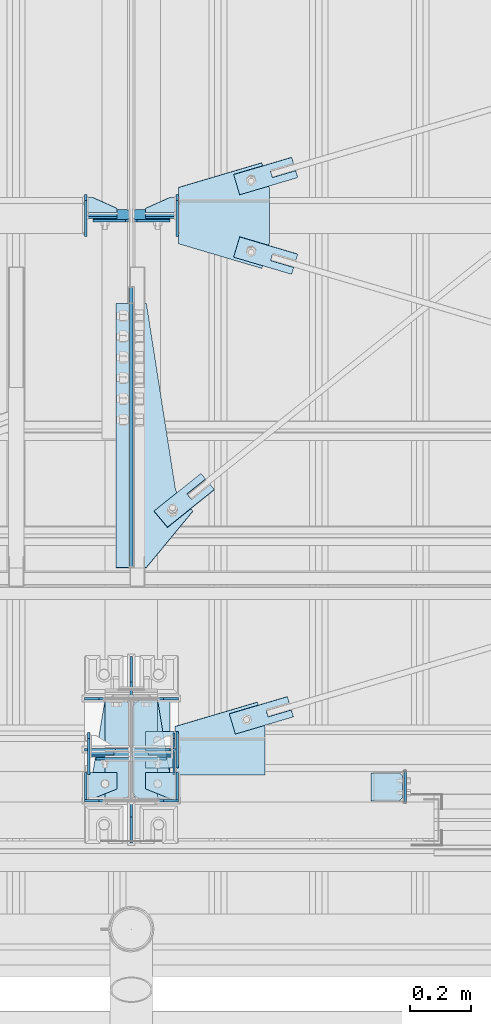
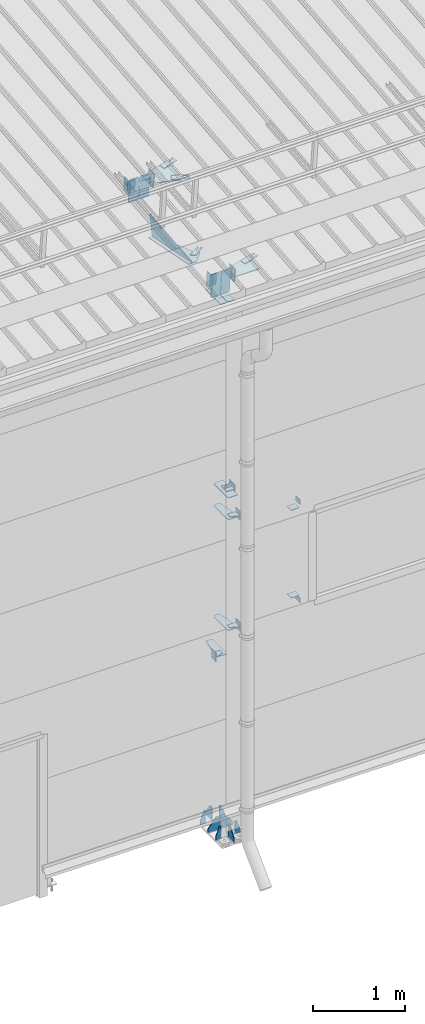
# One storey, part 108 of 709: 49 plates, 3 openings, 15 elements without a shape of their own.
"""IFC4 building model written with IfcOpenShell, lengths in millimetres."""

import ifcopenshell
import ifcopenshell.guid

model = None  # the IFC model being written
_history = None  # IfcOwnerHistory: only IFC2X3 demands one
_inside = {}  # id of a spatial element -> (the spatial element, [elements in it])
_under = {}  # id of a project, library or spatial element -> (it, [spatial elements below it])
_declared = {}  # id of a project -> (the project, [libraries it declares])
_typed = {}  # id of a type object -> (the type object, [elements of that type])
_made_of = {}  # id of a material, layer set ... -> (it, [elements and type objects made of it])


def new_model(schema):
    """Start an empty IFC model of exactly this schema.

    Asked for "IFC4X3", IfcOpenShell would pick the latest addendum, in which some entities
    have other attributes; the version numbers below select the first issue.
    IFC2X3 requires an IfcOwnerHistory on every rooted entity: one is made here for all.
    """
    global model, _history
    if schema == "IFC4X3":
        model = ifcopenshell.file(schema_version=(4, 3, 0, 0))
    else:
        model = ifcopenshell.file(schema=schema)
    _inside.clear()
    _under.clear()
    _declared.clear()
    _typed.clear()
    _made_of.clear()
    _history = None
    if model.schema == "IFC2X3":
        org = make("IfcOrganization", Name="unknown")
        user = make(
            "IfcPersonAndOrganization",
            ThePerson=make("IfcPerson", FamilyName="unknown"),
            TheOrganization=org,
        )
        app = make(
            "IfcApplication",
            ApplicationDeveloper=org,
            Version="unknown",
            ApplicationFullName="unknown",
            ApplicationIdentifier="unknown",
        )
        _history = make(
            "IfcOwnerHistory",
            OwningUser=user,
            OwningApplication=app,
            ChangeAction="ADDED",
            CreationDate=0,
        )
    return model


def make(cls, **values):
    """One entity of the class cls with the attributes given. An attribute that is None is left unset."""
    return model.create_entity(
        cls, **{name: value for name, value in values.items() if value is not None}
    )


def rooted(cls, **values):
    """An entity with a GlobalId (a new one), such as an element, a storey or a relation."""
    return make(cls, GlobalId=ifcopenshell.guid.new(), OwnerHistory=_history, **values)


def si_unit(unit_type, name, prefix=None):
    """IfcSIUnit, for example si_unit("LENGTHUNIT", "METRE", prefix="MILLI")."""
    return make("IfcSIUnit", UnitType=unit_type, Prefix=prefix, Name=name)


def assignment(units):
    """IfcUnitAssignment: the units of a project."""
    return None if units is None else make("IfcUnitAssignment", Units=units)


def point(xyz):
    """IfcCartesianPoint."""
    return None if xyz is None else make("IfcCartesianPoint", Coordinates=xyz)


def direction(xyz):
    """IfcDirection."""
    return None if xyz is None else make("IfcDirection", DirectionRatios=xyz)


def frame(location, z_axis=None, x_axis=None):
    """IfcAxis2Placement3D, a coordinate frame: its origin and axes. An axis left out is left unset."""
    return make(
        "IfcAxis2Placement3D",
        Location=point(location),
        Axis=direction(z_axis),
        RefDirection=direction(x_axis),
    )


def origin_with_axes():
    """The frame at (0, 0, 0) with the z axis (0, 0, 1) and the x axis (1, 0, 0) written out."""
    return frame((0.0, 0.0, 0.0), z_axis=(0.0, 0.0, 1.0), x_axis=(1.0, 0.0, 0.0))


def place(relative_to, where):
    """IfcLocalPlacement: puts the frame where relative to a parent placement (None: the world)."""
    return make(
        "IfcLocalPlacement", PlacementRelTo=relative_to, RelativePlacement=where
    )


def context(
    kind, dimensions, precision=None, world=None, true_north=None, identifier=None
):
    """IfcGeometricRepresentationContext, for example the 3D "Model" context."""
    return make(
        "IfcGeometricRepresentationContext",
        ContextIdentifier=identifier,
        ContextType=kind,
        CoordinateSpaceDimension=dimensions,
        Precision=precision,
        WorldCoordinateSystem=world,
        TrueNorth=true_north,
    )


def subcontext(parent, identifier, kind, view, scale=None):
    """IfcGeometricRepresentationSubContext, for example "Body" below "Model"."""
    return make(
        "IfcGeometricRepresentationSubContext",
        ContextIdentifier=identifier,
        ContextType=kind,
        ParentContext=parent,
        TargetScale=scale,
        TargetView=view,
    )


def project(units=None, contexts=None):
    """IfcProject with its units and contexts."""
    return rooted(
        "IfcProject",
        Name="project",
        RepresentationContexts=contexts,
        UnitsInContext=assignment(units),
    )


def spatial(cls, under=None, at=None, **own):
    """A site, building, storey or space (cls), placed at a placement, below another one or the project."""
    s = rooted(cls, ObjectPlacement=at, **own)
    if under is not None:
        _under.setdefault(under.id(), (under, []))[1].append(s)
    return s


def point_list(points):
    """IfcCartesianPointList2D or 3D."""
    cls = (
        "IfcCartesianPointList2D" if len(points[0]) == 2 else "IfcCartesianPointList3D"
    )
    return make(cls, CoordList=points)


def line(*indices):
    """IfcLineIndex: a straight run through numbered points of an indexed curve."""
    return model.create_entity("IfcLineIndex", indices)


def indexed_curve(points, segments=None, self_intersect=None):
    """IfcIndexedPolyCurve: lines and arcs through numbered points (the first is 1)."""
    return make(
        "IfcIndexedPolyCurve",
        Points=point_list(points),
        Segments=segments,
        SelfIntersect=self_intersect,
    )


def outline(outer, holes=None, kind="AREA"):
    """IfcArbitraryClosedProfileDef: a profile drawn as a closed curve; with holes, ...WithVoids."""
    if holes is None:
        return make("IfcArbitraryClosedProfileDef", ProfileType=kind, OuterCurve=outer)
    return make(
        "IfcArbitraryProfileDefWithVoids",
        ProfileType=kind,
        OuterCurve=outer,
        InnerCurves=holes,
    )


def extrude(swept, where, along, depth):
    """IfcExtrudedAreaSolid: the profile swept, set in the frame where, extruded along a direction by depth."""
    return make(
        "IfcExtrudedAreaSolid",
        SweptArea=swept,
        Position=where,
        ExtrudedDirection=direction(along),
        Depth=depth,
    )


def shape(context_of_items, identifier, shape_type, items):
    """IfcShapeRepresentation: the items that make up one representation, for example the "Body"."""
    return make(
        "IfcShapeRepresentation",
        ContextOfItems=context_of_items,
        RepresentationIdentifier=identifier,
        RepresentationType=shape_type,
        Items=items,
    )


def material(Name=None, Category=None):
    """IfcMaterial."""
    return make("IfcMaterial", Name=Name, Category=Category)


def made_of(thing, what):
    """Note that an element or type object is made of a material, layer set ...; save() writes the relation."""
    if what is not None:
        _made_of.setdefault(what.id(), (what, []))[1].append(thing)
    return thing


def element(
    cls,
    number,
    at=None,
    inside=None,
    cuts=None,
    type_object=None,
    material=None,
    context=None,
    identifier="Body",
    shape_type=None,
    held_by="IfcProductDefinitionShape",
    body=None,
    shapes=None,
    **own,
):
    """One element of the class cls, such as IfcWall. Its Tag is "e" and its number.

    at: its placement. inside: the storey or other place that contains it. cuts: it is an
    opening in that element (IfcRelVoidsElement). A single representation is given by context,
    identifier, shape_type and body (its items); several are given by shapes. held_by: the class
    of the entity that holds the representations. save() writes the other relations.
    """
    e = rooted(cls, Tag="e%d" % number, ObjectPlacement=at, **own)
    if body is not None:
        shapes = [shape(context, identifier, shape_type, body)]
    if shapes is not None:
        e.Representation = make(held_by, Representations=shapes)
    if inside is not None:
        _inside.setdefault(inside.id(), (inside, []))[1].append(e)
    if cuts is not None:
        rooted(
            "IfcRelVoidsElement", RelatingBuildingElement=cuts, RelatedOpeningElement=e
        )
    if type_object is not None:
        _typed.setdefault(type_object.id(), (type_object, []))[1].append(e)
    return made_of(e, material)


def aggregate(whole, parts):
    """IfcRelAggregates: a whole, such as a stair, and the parts it consists of."""
    return rooted("IfcRelAggregates", RelatingObject=whole, RelatedObjects=parts)


def save(model, path):
    """Write the relations noted so far, then the file.

    IfcRelAggregates (storeys below a building ...), IfcRelContainedInSpatialStructure (elements
    in a storey), IfcRelDefinesByType, IfcRelAssociatesMaterial and IfcRelDeclares: one each for
    every whole, place, type object, material and project.
    """
    for whole, parts in _under.values():
        aggregate(whole, parts)
    for where, things in _inside.values():
        rooted(
            "IfcRelContainedInSpatialStructure",
            RelatedElements=things,
            RelatingStructure=where,
        )
    for kind, things in _typed.values():
        rooted("IfcRelDefinesByType", RelatedObjects=things, RelatingType=kind)
    for what, things in _made_of.values():
        rooted("IfcRelAssociatesMaterial", RelatedObjects=things, RelatingMaterial=what)
    for by, libraries in _declared.values():
        rooted("IfcRelDeclares", RelatingContext=by, RelatedDefinitions=libraries)
    model.write(path)


model = new_model("IFC4")

# Units and contexts
model_context = context("Model", 3, precision=0.2, world=origin_with_axes(), true_north=direction((0.0, 1.0)))
body_context = subcontext(model_context, "Body", "Model", "MODEL_VIEW")
ifc_project = project(units=[si_unit("LENGTHUNIT", "METRE", prefix="MILLI"), si_unit("AREAUNIT", "SQUARE_METRE"), si_unit("VOLUMEUNIT", "CUBIC_METRE"), si_unit("MASSUNIT", "GRAM", prefix="KILO"), si_unit("TIMEUNIT", "SECOND"), si_unit("PLANEANGLEUNIT", "RADIAN"), si_unit("SOLIDANGLEUNIT", "STERADIAN"), si_unit("THERMODYNAMICTEMPERATUREUNIT", "DEGREE_CELSIUS"), si_unit("LUMINOUSINTENSITYUNIT", "LUMEN")], contexts=[model_context])

# Site, building, storey
site_placement = place(None, origin_with_axes())
site = spatial("IfcSite", under=ifc_project, at=site_placement, CompositionType="ELEMENT")
building_placement = place(site_placement, origin_with_axes())
building = spatial("IfcBuilding", under=site, at=building_placement, Name="Undefined", CompositionType="ELEMENT")
storey_placement = place(building_placement, origin_with_axes())
storey = spatial("IfcBuildingStorey", under=building, at=storey_placement, Name="Undefined", CompositionType="ELEMENT", Elevation=0.0)

# Assembly, plates
assembly_1_placement = place(storey_placement, frame((4000.0, 173.0, -200.0), z_axis=(-1.0, 0.0, 0.0), x_axis=(0.0, 0.0, 1.0)))
assembly_1 = element("IfcElementAssembly", 1, at=assembly_1_placement, inside=storey)
ifc_material = material(Name="C355-6", Category="STEEL")
plate_1_placement = place(assembly_1_placement, frame((25.0, -168.5, -87.0), z_axis=(0.0, -1.0, 0.0), x_axis=(0.0, 0.0, -1.0)))
plate_1 = element("IfcPlate", 2, at=plate_1_placement, material=ifc_material, ObjectType="419", context=body_context, shape_type="SolidModel", body=[
    extrude(outline(indexed_curve([(0.0, 0.0), (68.0, 0.0), (68.0, 50.0), (20.0, 175.0), (0.0, 175.0)], segments=[line(1, 2, 3, 4, 5, 1)])), frame((0.0, 0.0, 4.0), z_axis=(0.0, 0.0, 1.0), x_axis=(1.0, 0.0, 0.0)), (0.0, 0.0, -1.0), 8.0),
])
plate_2_placement = place(assembly_1_placement, frame((25.0, 168.5, -87.0), z_axis=(0.0, -1.0, 0.0), x_axis=(0.0, 0.0, -1.0)))
plate_2 = element("IfcPlate", 3, at=plate_2_placement, material=ifc_material, ObjectType="419", context=body_context, shape_type="SolidModel", body=[
    extrude(outline(indexed_curve([(0.0, 0.0), (68.0, 0.0), (68.0, 50.0), (20.0, 175.0), (0.0, 175.0)], segments=[line(1, 2, 3, 4, 5, 1)])), frame((0.0, 0.0, 4.0), z_axis=(0.0, 0.0, 1.0), x_axis=(1.0, 0.0, 0.0)), (0.0, 0.0, -1.0), 8.0),
])
plate_3_placement = place(assembly_1_placement, frame((25.0, 168.5, 87.0), z_axis=(0.0, 1.0, 0.0), x_axis=(0.0, 0.0, 1.0)))
plate_3 = element("IfcPlate", 4, at=plate_3_placement, material=ifc_material, ObjectType="419", context=body_context, shape_type="SolidModel", body=[
    extrude(outline(indexed_curve([(0.0, 0.0), (68.0, 0.0), (68.0, 50.0), (20.0, 175.0), (0.0, 175.0)], segments=[line(1, 2, 3, 4, 5, 1)])), frame((0.0, 0.0, 4.0), z_axis=(0.0, 0.0, 1.0), x_axis=(1.0, 0.0, 0.0)), (0.0, 0.0, -1.0), 8.0),
])
plate_4_placement = place(assembly_1_placement, frame((25.0, -168.5, 87.0), z_axis=(0.0, 1.0, 0.0), x_axis=(0.0, 0.0, 1.0)))
plate_4 = element("IfcPlate", 5, at=plate_4_placement, material=ifc_material, ObjectType="419", context=body_context, shape_type="SolidModel", body=[
    extrude(outline(indexed_curve([(0.0, 0.0), (68.0, 0.0), (68.0, 50.0), (20.0, 175.0), (0.0, 175.0)], segments=[line(1, 2, 3, 4, 5, 1)])), frame((0.0, 0.0, 4.0), z_axis=(0.0, 0.0, 1.0), x_axis=(1.0, 0.0, 0.0)), (0.0, 0.0, -1.0), 8.0),
])
plate_5_placement = place(assembly_1_placement, frame((25.0, 0.0, 3.0), z_axis=(0.0, 1.0, 0.0), x_axis=(0.0, 0.0, 1.0)))
plate_5 = element("IfcPlate", 6, at=plate_5_placement, material=ifc_material, ObjectType="417", context=body_context, shape_type="SolidModel", body=[
    extrude(outline(indexed_curve([(0.0, 0.0), (152.0, 0.0), (152.0, 50.0), (50.0, 175.0), (0.0, 175.0)], segments=[line(1, 2, 3, 4, 5, 1)])), frame((0.0, 0.0, 4.0), z_axis=(0.0, 0.0, 1.0), x_axis=(1.0, 0.0, 0.0)), (0.0, 0.0, -1.0), 8.0),
])
plate_6_placement = place(assembly_1_placement, frame((25.0, 173.0, 0.0), z_axis=(0.0, 0.0, -1.0), x_axis=(0.0, 1.0, 0.0)))
plate_6 = element("IfcPlate", 7, at=plate_6_placement, material=ifc_material, ObjectType="418", context=body_context, shape_type="SolidModel", body=[
    extrude(outline(indexed_curve([(0.0, 0.0), (135.0, 0.0), (135.0, 50.0), (50.0, 175.0), (0.0, 175.0)], segments=[line(1, 2, 3, 4, 5, 1)])), frame((0.0, 0.0, 4.0), z_axis=(0.0, 0.0, 1.0), x_axis=(1.0, 0.0, 0.0)), (0.0, 0.0, -1.0), 8.0),
])
plate_7_placement = place(assembly_1_placement, frame((25.0, -173.0, 0.0), z_axis=(0.0, 0.0, 1.0), x_axis=(0.0, -1.0, 0.0)))
plate_7 = element("IfcPlate", 8, at=plate_7_placement, material=ifc_material, ObjectType="418", context=body_context, shape_type="SolidModel", body=[
    extrude(outline(indexed_curve([(0.0, 0.0), (135.0, 0.0), (135.0, 50.0), (50.0, 175.0), (0.0, 175.0)], segments=[line(1, 2, 3, 4, 5, 1)])), frame((0.0, 0.0, 4.0), z_axis=(0.0, 0.0, 1.0), x_axis=(1.0, 0.0, 0.0)), (0.0, 0.0, -1.0), 8.0),
])
plate_8_placement = place(assembly_1_placement, frame((25.0, 0.0, -3.0), z_axis=(0.0, -1.0, 0.0), x_axis=(0.0, 0.0, -1.0)))
plate_8 = element("IfcPlate", 9, at=plate_8_placement, material=ifc_material, ObjectType="417", context=body_context, shape_type="SolidModel", body=[
    extrude(outline(indexed_curve([(0.0, 0.0), (152.0, 0.0), (152.0, 50.0), (50.0, 175.0), (0.0, 175.0)], segments=[line(1, 2, 3, 4, 5, 1)])), frame((0.0, 0.0, 4.0), z_axis=(0.0, 0.0, 1.0), x_axis=(1.0, 0.0, 0.0)), (0.0, 0.0, -1.0), 8.0),
])
plate_9_placement = place(assembly_1_placement, frame((7097.93718, 163.0, 87.0), z_axis=(-1.0, 0.0, 0.0), x_axis=(0.0, 0.0, -1.0)))
plate_9 = element("IfcPlate", 10, at=plate_9_placement, material=ifc_material, ObjectType="461", context=body_context, shape_type="SolidModel", body=[
    extrude(outline(indexed_curve([(0.0, 0.0), (68.0, 0.0), (83.0, 15.0), (83.0, 311.0), (68.0, 326.0), (0.0, 326.0)], segments=[line(1, 2, 3, 4, 5, 6, 1)])), frame((0.0, 0.0, 4.0), z_axis=(0.0, 0.0, 1.0), x_axis=(1.0, 0.0, 0.0)), (0.0, 0.0, -1.0), 8.0),
])
plate_10_placement = place(assembly_1_placement, frame((7097.93718, -163.0, -87.0), z_axis=(-1.0, 0.0, 0.0), x_axis=(0.0, 0.0, 1.0)))
plate_10 = element("IfcPlate", 11, at=plate_10_placement, material=ifc_material, ObjectType="461", context=body_context, shape_type="SolidModel", body=[
    extrude(outline(indexed_curve([(0.0, 0.0), (68.0, 0.0), (83.0, 15.0), (83.0, 311.0), (68.0, 326.0), (0.0, 326.0)], segments=[line(1, 2, 3, 4, 5, 6, 1)])), frame((0.0, 0.0, 4.0), z_axis=(0.0, 0.0, 1.0), x_axis=(1.0, 0.0, 0.0)), (0.0, 0.0, -1.0), 8.0),
])
plate_11_placement = place(assembly_1_placement, frame((2442.0, 163.0, 4.0), z_axis=(1.0, 0.0, 0.0), x_axis=(0.0, 0.0, 1.0)))
plate_11 = element("IfcPlate", 12, at=plate_11_placement, material=ifc_material, ObjectType="543", context=body_context, shape_type="SolidModel", body=[
    extrude(outline(indexed_curve([(0.0, 20.0), (20.0, 0.0), (83.0, 0.0), (123.0, 240.0), (123.0, 326.0), (20.0, 326.0), (0.0, 306.0)], segments=[line(1, 2, 3, 4, 5, 6, 7, 1)])), frame((0.0, 0.0, 4.0), z_axis=(0.0, 0.0, 1.0), x_axis=(1.0, 0.0, 0.0)), (0.0, 0.0, -1.0), 8.0),
])
plate_12_placement = place(assembly_1_placement, frame((2742.0, -163.0, -4.0), z_axis=(1.0, 0.0, 0.0), x_axis=(0.0, 0.0, -1.0)))
plate_12 = element("IfcPlate", 13, at=plate_12_placement, material=ifc_material, ObjectType="543", context=body_context, shape_type="SolidModel", body=[
    extrude(outline(indexed_curve([(0.0, 20.0), (20.0, 0.0), (123.0, 0.0), (123.0, 86.0), (83.0, 326.0), (20.0, 326.0), (0.0, 306.0)], segments=[line(1, 2, 3, 4, 5, 6, 7, 1)])), frame((0.0, 0.0, 4.0), z_axis=(0.0, 0.0, 1.0), x_axis=(1.0, 0.0, 0.0)), (0.0, 0.0, -1.0), 8.0),
])
plate_13_placement = place(assembly_1_placement, frame((4212.0, -163.0, -4.0), z_axis=(1.0, 0.0, 0.0), x_axis=(0.0, 0.0, -1.0)))
plate_13 = element("IfcPlate", 14, at=plate_13_placement, material=ifc_material, ObjectType="543", context=body_context, shape_type="SolidModel", body=[
    extrude(outline(indexed_curve([(0.0, 20.0), (20.0, 0.0), (123.0, 0.0), (123.0, 86.0), (83.0, 326.0), (20.0, 326.0), (0.0, 306.0)], segments=[line(1, 2, 3, 4, 5, 6, 7, 1)])), frame((0.0, 0.0, 4.0), z_axis=(0.0, 0.0, 1.0), x_axis=(1.0, 0.0, 0.0)), (0.0, 0.0, -1.0), 8.0),
])
plate_14_placement = place(assembly_1_placement, frame((4502.0, -163.0, -127.0), z_axis=(-1.0, 0.0, 0.0), x_axis=(0.0, 0.0, 1.0)))
plate_14 = element("IfcPlate", 15, at=plate_14_placement, material=ifc_material, ObjectType="547", context=body_context, shape_type="SolidModel", body=[
    extrude(outline(indexed_curve([(0.0, 0.0), (108.0, 0.0), (123.0, 15.0), (123.0, 311.0), (108.0, 326.0), (0.0, 326.0)], segments=[line(1, 2, 3, 4, 5, 6, 1)])), frame((0.0, 0.0, 4.0), z_axis=(0.0, 0.0, 1.0), x_axis=(1.0, 0.0, 0.0)), (0.0, 0.0, -1.0), 8.0),
])
plate_15_placement = place(assembly_1_placement, frame((7434.21506, -30.02921, 3.0), z_axis=(-0.099503719, -0.9950371902, 0.0), x_axis=(0.0, 0.0, 1.0)))
plate_15 = element("IfcPlate", 16, at=plate_15_placement, material=ifc_material, ObjectType="581", context=body_context, shape_type="SolidModel", body=[
    extrude(outline(indexed_curve([(0.0, 0.0), (114.0, 0.0), (114.0, 333.33514), (0.0, 333.33514)], segments=[line(1, 2, 3, 4, 1)])), frame((0.0, 0.0, 4.0), z_axis=(0.0, 0.0, 1.0), x_axis=(1.0, 0.0, 0.0)), (0.0, 0.0, -1.0), 8.0),
])
plate_16_placement = place(assembly_1_placement, frame((7434.21546, -30.02526, -3.0), z_axis=(0.099503719, 0.9950371902, 0.0), x_axis=(0.0, 0.0, -1.0)))
plate_16 = element("IfcPlate", 17, at=plate_16_placement, material=ifc_material, ObjectType="595", context=body_context, shape_type="SolidModel", body=[
    extrude(outline(indexed_curve([(0.0, 0.0), (114.0, 0.0), (114.0, 332.53554), (0.0, 332.53554)], segments=[line(1, 2, 3, 4, 1)])), frame((0.0, 0.0, 4.0), z_axis=(0.0, 0.0, 1.0), x_axis=(1.0, 0.0, 0.0)), (0.0, 0.0, -1.0), 8.0),
])
aggregate(assembly_1, [plate_1, plate_2, plate_3, plate_4, plate_5, plate_6, plate_7, plate_8, plate_9, plate_10, plate_11, plate_12, plate_13, plate_14, plate_15, plate_16])

assembly_2_placement = place(storey_placement, frame((4000.0, 346.0, 7089.70002), z_axis=(1.0, 0.0, 0.0), x_axis=(0.0, 0.9950371902, 0.099503719)))
assembly_2 = element("IfcElementAssembly", 18, at=assembly_2_placement, inside=storey)
plate_17_placement = place(assembly_2_placement, frame((1597.88359, 163.0, 127.0), z_axis=(-1.0, 0.0, 0.0), x_axis=(0.0, 0.0, -1.0)))
plate_17 = element("IfcPlate", 19, at=plate_17_placement, material=ifc_material, ObjectType="585", context=body_context, shape_type="SolidModel", body=[
    extrude(outline(indexed_curve([(0.0, 0.0), (108.0, 0.0), (123.0, 15.0), (123.0, 311.0), (108.0, 326.0), (0.0, 326.0)], segments=[line(1, 2, 3, 4, 5, 6, 1)])), frame((0.0, 0.0, 4.0), z_axis=(0.0, 0.0, 1.0), x_axis=(1.0, 0.0, 0.0)), (0.0, 0.0, -1.0), 8.0),
])
plate_18_placement = place(assembly_2_placement, frame((1597.87962, 163.0, -127.0), z_axis=(1.0, 0.0, 0.0), x_axis=(0.0, 0.0, 1.0)))
plate_18 = element("IfcPlate", 20, at=plate_18_placement, material=ifc_material, ObjectType="585", context=body_context, shape_type="SolidModel", body=[
    extrude(outline(indexed_curve([(0.0, 0.0), (108.0, 0.0), (123.0, 15.0), (123.0, 311.0), (108.0, 326.0), (0.0, 326.0)], segments=[line(1, 2, 3, 4, 5, 6, 1)])), frame((0.0, 0.0, 4.0), z_axis=(0.0, 0.0, 1.0), x_axis=(1.0, 0.0, 0.0)), (0.0, 0.0, -1.0), 8.0),
])
plate_19_placement = place(assembly_2_placement, frame((1261.40018, -436.65536, -50.0), z_axis=(0.2927142719, 0.9561999556, 0.0), x_axis=(-0.9561999556, 0.2927142719, 0.0)))
plate_19 = element("IfcPlate", 21, at=plate_19_placement, material=ifc_material, ObjectType="489", context=body_context, shape_type="SolidModel", body=[
    extrude(outline(indexed_curve([(0.0, 0.0), (887.65935, 0.0), (887.65935, 100.0), (698.2863, 253.1922), (628.6057, 196.23068), (0.0, 100.0)], segments=[line(1, 2, 3, 4, 5, 6, 1)])), frame((0.0, 0.0, 4.0), z_axis=(0.0, 0.0, 1.0), x_axis=(1.0, 0.0, 0.0)), (0.0, 0.0, -1.0), 8.0),
])
plate_20_placement = place(assembly_2_placement, frame((1342.111, -173.0, 0.0), z_axis=(0.0, 0.0, 1.0), x_axis=(-1.0, 0.0, 0.0)))
plate_20 = element("IfcPlate", 22, at=plate_20_placement, material=ifc_material, ObjectType="449", context=body_context, shape_type="SolidModel", body=[
    extrude(outline(indexed_curve([(0.0, 0.0), (928.3198, 0.0), (79.53997, 259.83056)], segments=[line(1, 2, 3, 1)])), frame((0.0, 0.0, 6.0), z_axis=(0.0, 0.0, 1.0), x_axis=(1.0, 0.0, 0.0)), (0.0, 0.0, -1.0), 12.0),
])
aggregate(assembly_2, [plate_17, plate_18, plate_19, plate_20])

# Assembly, plate
assembly_3_placement = place(storey_placement, frame((4000.0, 855.54834, 6946.69226), z_axis=(0.625451877, -0.7802627439, 1e-10), x_axis=(0.7742288439, 0.6206151549, -0.124123031)))
assembly_3 = element("IfcElementAssembly", 23, at=assembly_3_placement, inside=storey)
plate_21_placement = place(assembly_3_placement, frame((325.65866, 5.35577, 34.5878), z_axis=(0.0, -0.9882227647, 0.1530221141), x_axis=(-1.0, 0.0, 0.0)))
plate_21 = element("IfcPlate", 24, at=plate_21_placement, material=ifc_material, ObjectType="490", context=body_context, shape_type="SolidModel", body=[
    extrude(outline(indexed_curve([(0.0, 0.0), (200.0, 0.0), (200.0, 70.0), (0.0, 70.0), (0.0, 46.0), (80.0, 46.0), (80.0, 24.0), (0.0, 24.0)], segments=[line(1, 2, 3, 4, 5, 6, 7, 8, 1)])), frame((0.0, 0.0, 4.0), z_axis=(0.0, 0.0, 1.0), x_axis=(1.0, 0.0, 0.0)), (0.0, 0.0, -1.0), 8.0),
])
aggregate(assembly_3, [plate_21])

# Assembly, plates
assembly_4_placement = place(storey_placement, frame((80.0, 50.0, 2250.0), z_axis=(0.0, 0.0, -1.0), x_axis=(1.0, 0.0, 0.0)))
assembly_4 = element("IfcElementAssembly", 25, at=assembly_4_placement, inside=storey)
plate_22_placement = place(assembly_4_placement, frame((3773.0, 47.0, 0.0), z_axis=(0.0, 0.0, 1.0), x_axis=(0.0, -1.0, 0.0)))
plate_22 = element("IfcPlate", 26, at=plate_22_placement, material=ifc_material, ObjectType="502", context=body_context, shape_type="SolidModel", body=[
    extrude(outline(indexed_curve([(0.0, 0.0), (94.0, 0.0), (94.0, 100.0), (40.0, 100.0), (0.0, 0.0)], segments=[line(1, 2, 3, 4, 5, 1)])), frame((0.0, 0.0, 4.0), z_axis=(0.0, 0.0, 1.0), x_axis=(1.0, 0.0, 0.0)), (0.0, 0.0, -1.0), 8.0),
])
plate_23_placement = place(assembly_4_placement, frame((3769.0, 47.0, -60.0), z_axis=(-1.0, 0.0, 0.0), x_axis=(0.0, -1.0, 0.0)))
plate_23 = element("IfcPlate", 27, at=plate_23_placement, material=ifc_material, ObjectType="501", context=body_context, shape_type="SolidModel", body=[
    extrude(outline(indexed_curve([(0.0, 0.0), (94.0, 0.0), (94.0, 120.0), (0.0, 120.0)], segments=[line(1, 2, 3, 4, 1)])), frame((0.0, 0.0, 4.0), z_axis=(0.0, 0.0, 1.0), x_axis=(1.0, 0.0, 0.0)), (0.0, 0.0, -1.0), 8.0),
])
aggregate(assembly_4, [plate_22, plate_23])

assembly_5_placement = place(storey_placement, frame((4000.0, 50.0, 2550.0), z_axis=(0.0, 0.0, -1.0), x_axis=(1.0, 0.0, 0.0)))
assembly_5 = element("IfcElementAssembly", 28, at=assembly_5_placement, inside=storey)
plate_24_placement = place(assembly_5_placement, frame((151.0, 47.0, -60.0), z_axis=(-1.0, 0.0, 0.0), x_axis=(0.0, -1.0, 0.0)))
plate_24 = element("IfcPlate", 29, at=plate_24_placement, material=ifc_material, ObjectType="501", context=body_context, shape_type="SolidModel", body=[
    extrude(outline(indexed_curve([(0.0, 0.0), (94.0, 0.0), (94.0, 120.0), (0.0, 120.0)], segments=[line(1, 2, 3, 4, 1)])), frame((0.0, 0.0, 4.0), z_axis=(0.0, 0.0, 1.0), x_axis=(1.0, 0.0, 0.0)), (0.0, 0.0, -1.0), 8.0),
])
plate_25_placement = place(assembly_5_placement, frame((47.0, 47.0, 0.0), z_axis=(0.0, 0.0, 1.0), x_axis=(0.0, -1.0, 0.0)))
plate_25 = element("IfcPlate", 30, at=plate_25_placement, material=ifc_material, ObjectType="502", context=body_context, shape_type="SolidModel", body=[
    extrude(outline(indexed_curve([(0.0, 100.0), (40.0, 0.0), (94.0, 0.0), (94.0, 100.0), (0.0, 100.0)], segments=[line(1, 2, 3, 4, 5, 1)])), frame((0.0, 0.0, 4.0), z_axis=(0.0, 0.0, 1.0), x_axis=(1.0, 0.0, 0.0)), (0.0, 0.0, -1.0), 8.0),
])
plate_26_placement = place(assembly_5_placement, frame((904.0, 50.0, -50.0), z_axis=(-1.0, 0.0, 0.0), x_axis=(0.0, 0.0, -1.0)))
plate_26 = element("IfcPlate", 31, at=plate_26_placement, material=ifc_material, ObjectType="509", context=body_context, shape_type="SolidModel", body=[
    extrude(outline(indexed_curve([(0.0, 0.0), (65.0, 0.0), (65.0, 100.0), (0.0, 100.0)], segments=[line(1, 2, 3, 4, 1)])), frame((0.0, 0.0, 4.0), z_axis=(0.0, 0.0, 1.0), x_axis=(1.0, 0.0, 0.0)), (0.0, 0.0, -1.0), 8.0),
])
aggregate(assembly_5, [plate_24, plate_25, plate_26])

assembly_6_placement = place(storey_placement, frame((4000.0, 50.0, 4020.0), z_axis=(0.0, 0.0, -1.0), x_axis=(1.0, 0.0, 0.0)))
assembly_6 = element("IfcElementAssembly", 32, at=assembly_6_placement, inside=storey)
plate_27_placement = place(assembly_6_placement, frame((904.0, -50.0, 50.0), z_axis=(-1.0, 0.0, 0.0), x_axis=(0.0, 0.0, 1.0)))
plate_27 = element("IfcPlate", 33, at=plate_27_placement, material=ifc_material, ObjectType="509", context=body_context, shape_type="SolidModel", body=[
    extrude(outline(indexed_curve([(0.0, 0.0), (65.0, 0.0), (65.0, 100.0), (0.0, 100.0)], segments=[line(1, 2, 3, 4, 1)])), frame((0.0, 0.0, 4.0), z_axis=(0.0, 0.0, 1.0), x_axis=(1.0, 0.0, 0.0)), (0.0, 0.0, -1.0), 8.0),
])
plate_28_placement = place(assembly_6_placement, frame((47.0, 47.0, 0.0), z_axis=(0.0, 0.0, 1.0), x_axis=(0.0, -1.0, 0.0)))
plate_28 = element("IfcPlate", 34, at=plate_28_placement, material=ifc_material, ObjectType="502", context=body_context, shape_type="SolidModel", body=[
    extrude(outline(indexed_curve([(0.0, 100.0), (40.0, 0.0), (94.0, 0.0), (94.0, 100.0), (0.0, 100.0)], segments=[line(1, 2, 3, 4, 5, 1)])), frame((0.0, 0.0, 4.0), z_axis=(0.0, 0.0, 1.0), x_axis=(1.0, 0.0, 0.0)), (0.0, 0.0, -1.0), 8.0),
])
plate_29_placement = place(assembly_6_placement, frame((151.0, 47.0, -60.0), z_axis=(-1.0, 0.0, 0.0), x_axis=(0.0, -1.0, 0.0)))
plate_29 = element("IfcPlate", 35, at=plate_29_placement, material=ifc_material, ObjectType="501", context=body_context, shape_type="SolidModel", body=[
    extrude(outline(indexed_curve([(0.0, 0.0), (94.0, 0.0), (94.0, 120.0), (0.0, 120.0)], segments=[line(1, 2, 3, 4, 1)])), frame((0.0, 0.0, 4.0), z_axis=(0.0, 0.0, 1.0), x_axis=(1.0, 0.0, 0.0)), (0.0, 0.0, -1.0), 8.0),
])
aggregate(assembly_6, [plate_27, plate_28, plate_29])

assembly_7_placement = place(storey_placement, frame((4850.0, 50.0, 2600.0), z_axis=(1.0, 0.0, 0.0), x_axis=(0.0, 0.0, 1.0)))
assembly_7 = element("IfcElementAssembly", 36, at=assembly_7_placement, inside=storey)
plate_30_placement = place(assembly_7_placement, frame((103.0, -46.0, 46.0), z_axis=(-1.0, 0.0, 0.0), x_axis=(0.0, 1.0, 0.0)))
plate_30 = element("IfcPlate", 37, at=plate_30_placement, material=ifc_material, ObjectType="510", context=body_context, shape_type="SolidModel", body=[
    extrude(outline(indexed_curve([(0.0, 10.0), (10.0, 0.0), (82.0, 0.0), (92.0, 10.0), (92.0, 104.0), (0.0, 104.0)], segments=[line(1, 2, 3, 4, 5, 6, 1)])), frame((0.0, 0.0, 4.0), z_axis=(0.0, 0.0, 1.0), x_axis=(1.0, 0.0, 0.0)), (0.0, 0.0, -1.0), 8.0),
])
plate_31_placement = place(assembly_7_placement, frame((1267.0, 46.0, 46.0), z_axis=(1.0, 0.0, 0.0), x_axis=(0.0, -1.0, 0.0)))
plate_31 = element("IfcPlate", 38, at=plate_31_placement, material=ifc_material, ObjectType="510", context=body_context, shape_type="SolidModel", body=[
    extrude(outline(indexed_curve([(0.0, 10.0), (10.0, 0.0), (82.0, 0.0), (92.0, 10.0), (92.0, 104.0), (0.0, 104.0)], segments=[line(1, 2, 3, 4, 5, 6, 1)])), frame((0.0, 0.0, 4.0), z_axis=(0.0, 0.0, 1.0), x_axis=(1.0, 0.0, 0.0)), (0.0, 0.0, -1.0), 8.0),
])
aggregate(assembly_7, [plate_30, plate_31])

assembly_8_placement = place(storey_placement, frame((4000.0, 173.0, 4310.0), z_axis=(0.0, 0.0, -1.0), x_axis=(1.0, 0.0, 0.0)))
assembly_8 = element("IfcElementAssembly", 39, at=assembly_8_placement, inside=storey)
plate_32_placement = place(assembly_8_placement, frame((47.0, 0.0, -60.0), z_axis=(0.0, 1.0, 0.0), x_axis=(0.0, 0.0, 1.0)))
plate_32 = element("IfcPlate", 40, at=plate_32_placement, material=ifc_material, ObjectType="508", context=body_context, shape_type="SolidModel", body=[
    extrude(outline(indexed_curve([(0.0, 80.0), (36.0, 0.0), (56.0, 0.0), (56.0, 90.0), (46.0, 100.0), (0.0, 100.0)], segments=[line(1, 2, 3, 4, 5, 6, 1)])), frame((0.0, 0.0, 4.0), z_axis=(0.0, 0.0, 1.0), x_axis=(1.0, 0.0, 0.0)), (0.0, 0.0, -1.0), 8.0),
])
plate_33_placement = place(assembly_8_placement, frame((47.0, 60.0, 0.0), z_axis=(0.0, 0.0, 1.0), x_axis=(0.0, -1.0, 0.0)))
plate_33 = element("IfcPlate", 41, at=plate_33_placement, material=ifc_material, ObjectType="507", context=body_context, shape_type="SolidModel", body=[
    extrude(outline(indexed_curve([(0.0, 0.0), (120.0, 0.0), (120.0, 100.0), (0.0, 100.0)], segments=[line(1, 2, 3, 4, 1)])), frame((0.0, 0.0, 4.0), z_axis=(0.0, 0.0, 1.0), x_axis=(1.0, 0.0, 0.0)), (0.0, 0.0, -1.0), 8.0),
])
plate_34_placement = place(assembly_8_placement, frame((151.0, 60.0, 60.0), z_axis=(-1.0, 0.0, 0.0), x_axis=(0.0, 0.0, -1.0)))
plate_34 = element("IfcPlate", 42, at=plate_34_placement, material=ifc_material, ObjectType="506", context=body_context, shape_type="SolidModel", body=[
    extrude(outline(indexed_curve([(0.0, 0.0), (120.0, 0.0), (120.0, 120.0), (0.0, 120.0)], segments=[line(1, 2, 3, 4, 1)])), frame((0.0, 0.0, 4.0), z_axis=(0.0, 0.0, 1.0), x_axis=(1.0, 0.0, 0.0)), (0.0, 0.0, -1.0), 8.0),
])
aggregate(assembly_8, [plate_32, plate_33, plate_34])

# Assembly, plate, voiding feature
assembly_9_placement = place(storey_placement, frame((4000.0, 159.15434, 7152.41945), z_axis=(0.2852311229, -0.9537021177, -0.0953702118), x_axis=(0.9584587662, 0.2838155751, 0.028381558)))
assembly_9 = element("IfcElementAssembly", 43, at=assembly_9_placement, inside=storey)
plate_35_placement = place(assembly_9_placement, frame((348.0251, 0.0, -35.0), z_axis=(0.0, 1.0, 0.0), x_axis=(0.0, 0.0, 1.0)))
plate_35 = element("IfcPlate", 44, at=plate_35_placement, material=ifc_material, ObjectType="574", context=body_context, shape_type="SolidModel", body=[
    extrude(outline(indexed_curve([(0.0, 0.0), (70.0, 0.0), (70.0, 200.0), (0.0, 200.0)], segments=[line(1, 2, 3, 4, 1)])), frame((0.0, 0.0, 4.0), z_axis=(0.0, 0.0, 1.0), x_axis=(1.0, 0.0, 0.0)), (0.0, 0.0, -1.0), 8.0),
])
voiding_feature_1_placement = place(plate_35_placement, frame((24.0, 120.0, 0.0), z_axis=(0.0, 0.0, 1.0), x_axis=(1.0, 0.0, 0.0)))
element("IfcVoidingFeature", 45, at=voiding_feature_1_placement, cuts=plate_35, Name="PLATE", PredefinedType="HOLE", context=body_context, shape_type="SolidModel", body=[
    extrude(outline(indexed_curve([(0.0, 0.0), (22.0, 0.0), (22.0, 85.0), (0.0, 85.0)], segments=[line(1, 2, 3, 4, 1)])), frame((0.0, 0.0, 6.5), z_axis=(0.0, 0.0, 1.0), x_axis=(1.0, 0.0, 0.0)), (0.0, 0.0, -1.0), 13.0),
])
aggregate(assembly_9, [plate_35])

assembly_10_placement = place(storey_placement, frame((4000.0, 1935.85409, 7330.08943), z_axis=(-0.2852311229, -0.9537021177, -0.0953702118), x_axis=(0.9584587662, -0.2838155751, -0.028381558)))
assembly_10 = element("IfcElementAssembly", 46, at=assembly_10_placement, inside=storey)
plate_36_placement = place(assembly_10_placement, frame((363.0251, 0.0, -35.0), z_axis=(0.0, 1.0, 0.0), x_axis=(0.0, 0.0, 1.0)))
plate_36 = element("IfcPlate", 47, at=plate_36_placement, material=ifc_material, ObjectType="574", context=body_context, shape_type="SolidModel", body=[
    extrude(outline(indexed_curve([(0.0, 0.0), (70.0, 0.0), (70.0, 200.0), (0.0, 200.0)], segments=[line(1, 2, 3, 4, 1)])), frame((0.0, 0.0, 4.0), z_axis=(0.0, 0.0, 1.0), x_axis=(1.0, 0.0, 0.0)), (0.0, 0.0, -1.0), 8.0),
])
voiding_feature_2_placement = place(plate_36_placement, frame((24.0, 120.0, 0.0), z_axis=(0.0, 0.0, 1.0), x_axis=(1.0, 0.0, 0.0)))
element("IfcVoidingFeature", 48, at=voiding_feature_2_placement, cuts=plate_36, Name="PLATE", PredefinedType="HOLE", context=body_context, shape_type="SolidModel", body=[
    extrude(outline(indexed_curve([(0.0, 0.0), (22.0, 0.0), (22.0, 85.0), (0.0, 85.0)], segments=[line(1, 2, 3, 4, 1)])), frame((0.0, 0.0, 6.5), z_axis=(0.0, 0.0, 1.0), x_axis=(1.0, 0.0, 0.0)), (0.0, 0.0, -1.0), 13.0),
])
aggregate(assembly_10, [plate_36])

assembly_11_placement = place(storey_placement, frame((4000.0, 1935.85409, 7330.08943), z_axis=(0.2852311229, -0.9537021177, -0.0953702118), x_axis=(0.9584587662, 0.2838155751, 0.028381558)))
assembly_11 = element("IfcElementAssembly", 49, at=assembly_11_placement, inside=storey)
plate_37_placement = place(assembly_11_placement, frame((363.0251, 0.0, -35.0), z_axis=(0.0, 1.0, 0.0), x_axis=(0.0, 0.0, 1.0)))
plate_37 = element("IfcPlate", 50, at=plate_37_placement, material=ifc_material, ObjectType="574", context=body_context, shape_type="SolidModel", body=[
    extrude(outline(indexed_curve([(0.0, 0.0), (70.0, 0.0), (70.0, 200.0), (0.0, 200.0)], segments=[line(1, 2, 3, 4, 1)])), frame((0.0, 0.0, 4.0), z_axis=(0.0, 0.0, 1.0), x_axis=(1.0, 0.0, 0.0)), (0.0, 0.0, -1.0), 8.0),
])
voiding_feature_3_placement = place(plate_37_placement, frame((24.0, 120.0, 0.0), z_axis=(0.0, 0.0, 1.0), x_axis=(1.0, 0.0, 0.0)))
element("IfcVoidingFeature", 51, at=voiding_feature_3_placement, cuts=plate_37, Name="PLATE", PredefinedType="HOLE", context=body_context, shape_type="SolidModel", body=[
    extrude(outline(indexed_curve([(0.0, 0.0), (22.0, 0.0), (22.0, 85.0), (0.0, 85.0)], segments=[line(1, 2, 3, 4, 1)])), frame((0.0, 0.0, 6.5), z_axis=(0.0, 0.0, 1.0), x_axis=(1.0, 0.0, 0.0)), (0.0, 0.0, -1.0), 13.0),
])
aggregate(assembly_11, [plate_37])

# Assembly, plates
assembly_12_placement = place(storey_placement, frame((0.0, 159.95037, 7144.41925), z_axis=(0.0, 0.9950371902, 0.099503719), x_axis=(1.0, 0.0, 0.0)))
assembly_12 = element("IfcElementAssembly", 52, at=assembly_12_placement, inside=storey)
plate_38_placement = place(assembly_12_placement, frame((3859.0, -97.0, 60.0), z_axis=(1.0, 0.0, 0.0), x_axis=(0.0, 0.0, -1.0)))
plate_38 = element("IfcPlate", 53, at=plate_38_placement, material=ifc_material, ObjectType="582", context=body_context, shape_type="SolidModel", body=[
    extrude(outline(indexed_curve([(0.0, 0.0), (120.0, 0.0), (120.0, 194.0), (0.0, 194.0)], segments=[line(1, 2, 3, 4, 1)])), frame((0.0, 0.0, 4.0), z_axis=(0.0, 0.0, 1.0), x_axis=(1.0, 0.0, 0.0)), (0.0, 0.0, -1.0), 8.0),
])
plate_39_placement = place(assembly_12_placement, frame((3943.0, 82.0, 0.0), z_axis=(0.0, 0.0, 1.0), x_axis=(-1.0, 0.0, 0.0)))
plate_39 = element("IfcPlate", 54, at=plate_39_placement, material=ifc_material, ObjectType="583", context=body_context, shape_type="SolidModel", body=[
    extrude(outline(indexed_curve([(0.0, 0.0), (80.0, 0.0), (80.0, 164.0), (0.0, 164.0)], segments=[line(1, 2, 3, 4, 1)])), frame((0.0, 0.0, 4.0), z_axis=(0.0, 0.0, 1.0), x_axis=(1.0, 0.0, 0.0)), (0.0, 0.0, -1.0), 8.0),
])
aggregate(assembly_12, [plate_38, plate_39])

assembly_13_placement = place(storey_placement, frame((0.0, 1936.65012, 7322.08923), z_axis=(0.0, 0.9950371902, 0.099503719), x_axis=(1.0, 0.0, 0.0)))
assembly_13 = element("IfcElementAssembly", 55, at=assembly_13_placement, inside=storey)
plate_40_placement = place(assembly_13_placement, frame((3849.0, -98.0, 60.0), z_axis=(1.0, 0.0, 0.0), x_axis=(0.0, 0.0, -1.0)))
plate_40 = element("IfcPlate", 56, at=plate_40_placement, material=ifc_material, ObjectType="586", context=body_context, shape_type="SolidModel", body=[
    extrude(outline(indexed_curve([(0.0, 0.0), (120.0, 0.0), (120.0, 196.0), (0.0, 196.0)], segments=[line(1, 2, 3, 4, 1)])), frame((0.0, 0.0, 4.0), z_axis=(0.0, 0.0, 1.0), x_axis=(1.0, 0.0, 0.0)), (0.0, 0.0, -1.0), 8.0),
])
plate_41_placement = place(assembly_13_placement, frame((3953.0, 65.0, 0.0), z_axis=(0.0, 0.0, 1.0), x_axis=(-1.0, 0.0, 0.0)))
plate_41 = element("IfcPlate", 57, at=plate_41_placement, material=ifc_material, ObjectType="587", context=body_context, shape_type="SolidModel", body=[
    extrude(outline(indexed_curve([(0.0, 0.0), (100.0, 0.0), (100.0, 130.0), (0.0, 130.0)], segments=[line(1, 2, 3, 4, 1)])), frame((0.0, 0.0, 4.0), z_axis=(0.0, 0.0, 1.0), x_axis=(1.0, 0.0, 0.0)), (0.0, 0.0, -1.0), 8.0),
])
plate_42_placement = place(assembly_13_placement, frame((3953.0, 0.0, 60.0), z_axis=(0.0, -1.0, 0.0), x_axis=(-1.0, 0.0, 0.0)))
plate_42 = element("IfcPlate", 58, at=plate_42_placement, material=ifc_material, ObjectType="588", context=body_context, shape_type="SolidModel", body=[
    extrude(outline(indexed_curve([(0.0, 36.0), (80.0, 0.0), (100.0, 0.0), (100.0, 56.0), (0.0, 56.0)], segments=[line(1, 2, 3, 4, 5, 1)])), frame((0.0, 0.0, 4.0), z_axis=(0.0, 0.0, 1.0), x_axis=(1.0, 0.0, 0.0)), (0.0, 0.0, -1.0), 8.0),
])
aggregate(assembly_13, [plate_40, plate_41, plate_42])

assembly_14_placement = place(storey_placement, frame((4000.0, 158.95533, 7154.40952), z_axis=(0.0, 0.9950371902, 0.099503719), x_axis=(1.0, 0.0, 0.0)))
assembly_14 = element("IfcElementAssembly", 59, at=assembly_14_placement, inside=storey)
plate_43_placement = place(assembly_14_placement, frame((141.0, -87.0, -60.0), z_axis=(-1.0, 0.0, 0.0), x_axis=(0.0, 0.0, 1.0)))
plate_43 = element("IfcPlate", 60, at=plate_43_placement, material=ifc_material, ObjectType="596", context=body_context, shape_type="SolidModel", body=[
    extrude(outline(indexed_curve([(0.0, 0.0), (120.0, 0.0), (120.0, 174.0), (0.0, 174.0)], segments=[line(1, 2, 3, 4, 1)])), frame((0.0, 0.0, 4.0), z_axis=(0.0, 0.0, 1.0), x_axis=(1.0, 0.0, 0.0)), (0.0, 0.0, -1.0), 8.0),
])
plate_44_placement = place(assembly_14_placement, frame((145.0, 10.0, -70.0), z_axis=(0.0, -1.0, 0.0), x_axis=(1.0, 0.0, 0.0)))
plate_44 = element("IfcPlate", 61, at=plate_44_placement, material=ifc_material, Name="PLATE", ObjectType="575", context=body_context, shape_type="SolidModel", body=[
    extrude(outline(indexed_curve([(0.0, 0.0), (297.24898, 0.0), (297.24898, 154.66006), (271.57818, 240.92135), (0.0, 160.10144)], segments=[line(1, 2, 3, 4, 5, 1)])), frame((0.0, 0.0, 4.0), z_axis=(0.0, 0.0, 1.0), x_axis=(1.0, 0.0, 0.0)), (0.0, 0.0, -1.0), 8.0),
])
plate_45_placement = place(assembly_14_placement, frame((57.0, -72.0, 0.0), z_axis=(0.0, 0.0, 1.0), x_axis=(1.0, 0.0, 0.0)))
plate_45 = element("IfcPlate", 62, at=plate_45_placement, material=ifc_material, ObjectType="597", context=body_context, shape_type="SolidModel", body=[
    extrude(outline(indexed_curve([(0.0, 0.0), (80.0, 0.0), (80.0, 144.0), (0.0, 144.0)], segments=[line(1, 2, 3, 4, 1)])), frame((0.0, 0.0, 4.0), z_axis=(0.0, 0.0, 1.0), x_axis=(1.0, 0.0, 0.0)), (0.0, 0.0, -1.0), 8.0),
])
aggregate(assembly_14, [plate_43, plate_44, plate_45])

assembly_15_placement = place(storey_placement, frame((4000.0, 1936.65012, 7322.12913), z_axis=(0.0, 0.9950371902, 0.099503719), x_axis=(1.0, 0.0, 0.0)))
assembly_15 = element("IfcElementAssembly", 63, at=assembly_15_placement, inside=storey)
plate_46_placement = place(assembly_15_placement, frame((47.0, 0.0, 60.0), z_axis=(0.0, 1.0, 0.0), x_axis=(1.0, 0.0, 0.0)))
plate_46 = element("IfcPlate", 64, at=plate_46_placement, material=ifc_material, ObjectType="588", context=body_context, shape_type="SolidModel", body=[
    extrude(outline(indexed_curve([(0.0, 36.0), (80.0, 0.0), (100.0, 0.0), (100.0, 56.0), (0.0, 56.0)], segments=[line(1, 2, 3, 4, 5, 1)])), frame((0.0, 0.0, 4.0), z_axis=(0.0, 0.0, 1.0), x_axis=(1.0, 0.0, 0.0)), (0.0, 0.0, -1.0), 8.0),
])
plate_47_placement = place(assembly_15_placement, frame((47.0, -65.0, 0.0), z_axis=(0.0, 0.0, 1.0), x_axis=(1.0, 0.0, 0.0)))
plate_47 = element("IfcPlate", 65, at=plate_47_placement, material=ifc_material, ObjectType="587", context=body_context, shape_type="SolidModel", body=[
    extrude(outline(indexed_curve([(0.0, 0.0), (100.0, 0.0), (100.0, 130.0), (0.0, 130.0)], segments=[line(1, 2, 3, 4, 1)])), frame((0.0, 0.0, 4.0), z_axis=(0.0, 0.0, 1.0), x_axis=(1.0, 0.0, 0.0)), (0.0, 0.0, -1.0), 8.0),
])
plate_48_placement = place(assembly_15_placement, frame((151.0, -98.0, -60.0), z_axis=(-1.0, 0.0, 0.0), x_axis=(0.0, 0.0, 1.0)))
plate_48 = element("IfcPlate", 66, at=plate_48_placement, material=ifc_material, ObjectType="586", context=body_context, shape_type="SolidModel", body=[
    extrude(outline(indexed_curve([(0.0, 0.0), (120.0, 0.0), (120.0, 196.0), (0.0, 196.0)], segments=[line(1, 2, 3, 4, 1)])), frame((0.0, 0.0, 4.0), z_axis=(0.0, 0.0, 1.0), x_axis=(1.0, 0.0, 0.0)), (0.0, 0.0, -1.0), 8.0),
])
plate_49_placement = place(assembly_15_placement, frame((154.99945, 0.0, 93.07721), z_axis=(0.0, -1.0, 0.0), x_axis=(0.0, 0.0, -1.0)))
plate_49 = element("IfcPlate", 67, at=plate_49_placement, material=ifc_material, ObjectType="576", context=body_context, shape_type="SolidModel", body=[
    extrude(outline(indexed_curve([(0.0, 0.0), (186.15442, 0.0), (268.27702, 275.95562), (182.01573, 301.62642), (4.13868, 301.62642), (-82.1226, 275.95562)], segments=[line(1, 2, 3, 4, 5, 6, 1)])), frame((0.0, 0.0, 4.0), z_axis=(0.0, 0.0, 1.0), x_axis=(1.0, 0.0, 0.0)), (0.0, 0.0, -1.0), 8.0),
])
aggregate(assembly_15, [plate_46, plate_47, plate_48, plate_49])

save(model, "model.ifc")
